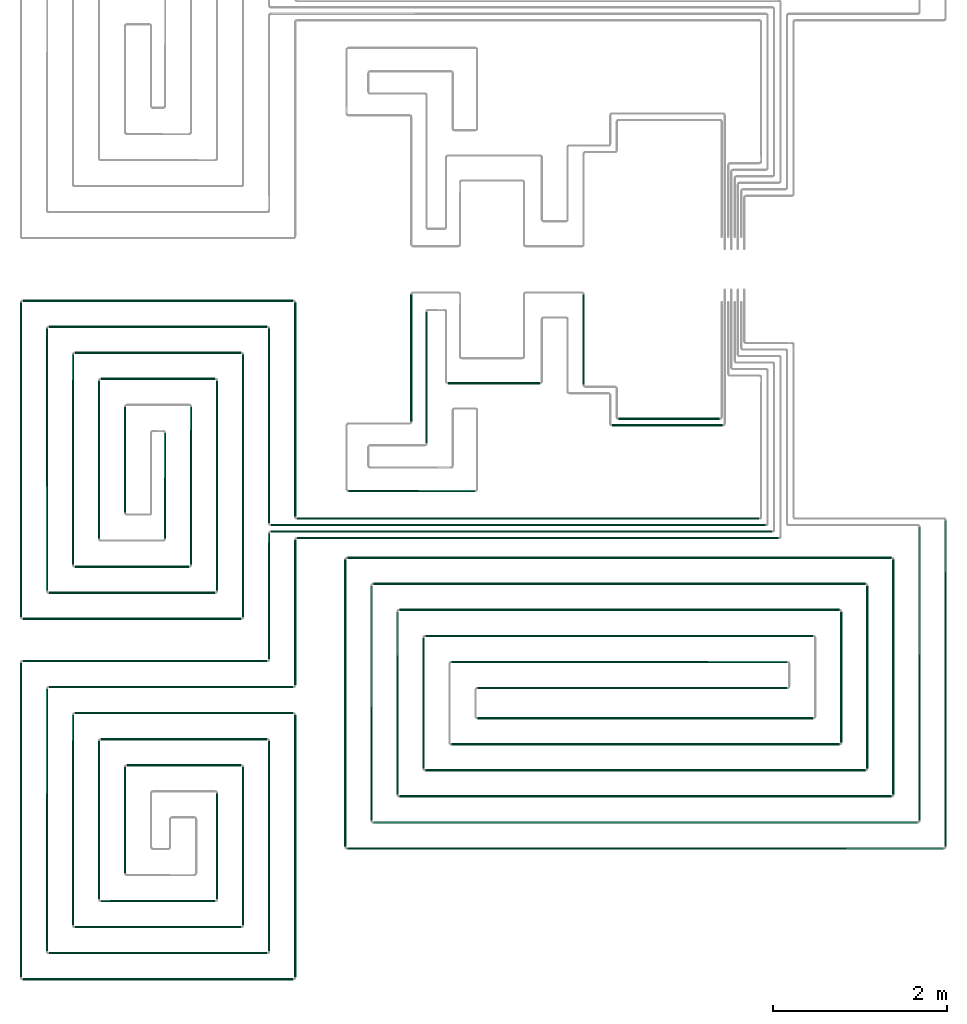
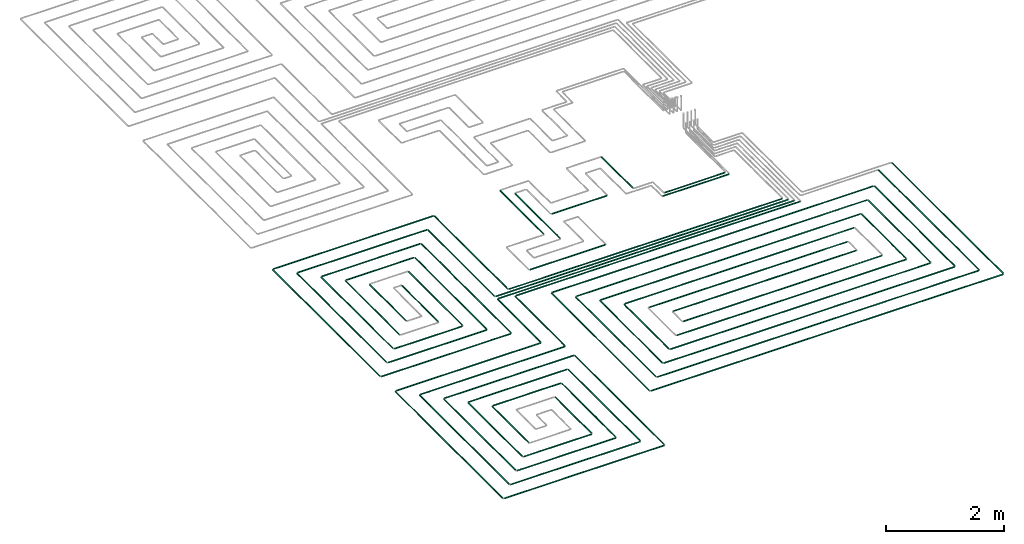
# One storey, part 1 of 12: 70 flow segments.
"""IFC2X3 building model written with IfcOpenShell, lengths in millimetres."""

from ifc_helpers import new_model, entity, si_unit, converted_unit, derived_unit, direction, frame, frame_2d, origin, origin_2d_with_axis, place, context, subcontext, project, spatial, circle, extrude, type_object, element, save


model = new_model("IFC2X3")

# Units and contexts
model_context = context("Model", 3, precision=0.01, world=origin(), true_north=direction((6.12303176911189e-17, 1.0)))
body_context = subcontext(model_context, "Body", "Model", "MODEL_VIEW")
ifc_project = project(units=[si_unit("LENGTHUNIT", "METRE", prefix="MILLI"), si_unit("AREAUNIT", "SQUARE_METRE"), si_unit("VOLUMEUNIT", "CUBIC_METRE"), converted_unit("PLANEANGLEUNIT", "DEGREE", entity("IfcRatioMeasure", 0.0174532925199433), si_unit("PLANEANGLEUNIT", "RADIAN"), dimensions=[0, 0, 0, 0, 0, 0, 0]), si_unit("MASSUNIT", "GRAM", prefix="KILO"), derived_unit("MASSDENSITYUNIT", [(si_unit("MASSUNIT", "GRAM", prefix="KILO"), 1), (si_unit("LENGTHUNIT", "METRE"), -3)]), si_unit("TIMEUNIT", "SECOND"), si_unit("FREQUENCYUNIT", "HERTZ"), si_unit("THERMODYNAMICTEMPERATUREUNIT", "DEGREE_CELSIUS"), derived_unit("THERMALTRANSMITTANCEUNIT", [(si_unit("MASSUNIT", "GRAM", prefix="KILO"), 1), (si_unit("THERMODYNAMICTEMPERATUREUNIT", "KELVIN"), -1), (si_unit("TIMEUNIT", "SECOND"), -3)]), derived_unit("VOLUMETRICFLOWRATEUNIT", [(si_unit("LENGTHUNIT", "METRE"), 3), (si_unit("TIMEUNIT", "SECOND"), -1)]), si_unit("ELECTRICCURRENTUNIT", "AMPERE"), si_unit("ELECTRICVOLTAGEUNIT", "VOLT"), si_unit("POWERUNIT", "WATT"), si_unit("FORCEUNIT", "NEWTON", prefix="KILO"), si_unit("ILLUMINANCEUNIT", "LUX"), si_unit("LUMINOUSFLUXUNIT", "LUMEN"), si_unit("LUMINOUSINTENSITYUNIT", "CANDELA"), derived_unit("USERDEFINED", [(si_unit("MASSUNIT", "GRAM", prefix="KILO"), -1), (si_unit("LENGTHUNIT", "METRE"), -2), (si_unit("TIMEUNIT", "SECOND"), 3), (si_unit("LUMINOUSFLUXUNIT", "LUMEN"), 1)]), derived_unit("LINEARVELOCITYUNIT", [(si_unit("LENGTHUNIT", "METRE"), 1), (si_unit("TIMEUNIT", "SECOND"), -1)]), si_unit("PRESSUREUNIT", "PASCAL"), derived_unit("USERDEFINED", [(si_unit("LENGTHUNIT", "METRE"), -2), (si_unit("MASSUNIT", "GRAM", prefix="KILO"), 1), (si_unit("TIMEUNIT", "SECOND"), -2)])], contexts=[model_context])

# Site, building, storey
site_placement = place(None, origin())
site = spatial("IfcSite", under=ifc_project, at=site_placement, CompositionType="ELEMENT")
building_placement = place(site_placement, origin())
building = spatial("IfcBuilding", under=site, at=building_placement, CompositionType="ELEMENT")
storey_placement = place(building_placement, frame((0.0, 0.0, 8000.0)))
storey = spatial("IfcBuildingStorey", under=building, at=storey_placement, Name="02 Level", CompositionType="ELEMENT", Elevation=8000.0)

# Flow segments
pipe_segment_type = type_object("IfcPipeSegmentType", PredefinedType="NOTDEFINED")
flow_segment_1_placement = place(storey_placement, frame((20884.4386293741, -71711.6450070283, -81.595272235917)))
element("IfcFlowSegment", 1, at=flow_segment_1_placement, inside=storey, type_object=pipe_segment_type, context=body_context, shape_type="SweptSolid", body=[
    extrude(circle(Radius=10.0, at=frame_2d((-8.66293703438714e-12, 0.0), x_axis=(1.0, 0.0))), frame((0.0, 11.5952722359136, 11.5952722359158), z_axis=(1.0, 0.0, 0.0), x_axis=(0.0, 1.0, 0.0)), (0.0, 0.0, 1.0), 5324.24692007345),
])
flow_segment_2_placement = place(storey_placement, frame((20584.4386293741, -71786.6450070283, -81.5952722359161)))
element("IfcFlowSegment", 2, at=flow_segment_2_placement, inside=storey, type_object=pipe_segment_type, context=body_context, shape_type="SweptSolid", body=[
    extrude(circle(Radius=10.0, at=frame_2d((-8.66293703438714e-12, 0.0), x_axis=(1.0, 0.0))), frame((0.0, 11.5952722359223, 11.5952722359158), z_axis=(1.0, 0.0, 0.0), x_axis=(0.0, 1.0, 0.0)), (0.0, 0.0, 1.0), 5699.24692007345),
])
flow_segment_3_placement = place(storey_placement, frame((20584.4386293741, -71861.6450070283, -81.5952722359161)))
element("IfcFlowSegment", 3, at=flow_segment_3_placement, inside=storey, type_object=pipe_segment_type, context=body_context, shape_type="SweptSolid", body=[
    extrude(circle(Radius=10.0, at=frame_2d((-2.59888111031614e-11, 0.0), x_axis=(1.0, 0.0))), frame((0.0, 11.5952722359396, 11.5952722359158), z_axis=(1.0, 0.0, 0.0), x_axis=(0.0, 1.0, 0.0)), (0.0, 0.0, 1.0), 5774.24692007345),
])
flow_segment_4_placement = place(storey_placement, frame((20884.4386293741, -71936.6450070283, -81.5952722359161)))
element("IfcFlowSegment", 4, at=flow_segment_4_placement, inside=storey, type_object=pipe_segment_type, context=body_context, shape_type="SweptSolid", body=[
    extrude(circle(Radius=10.0, at=frame_2d((-1.73258740687743e-11, 0.0), x_axis=(1.0, 0.0))), frame((0.0, 11.595272235931, 11.5952722359158), z_axis=(1.0, 0.0, 0.0), x_axis=(0.0, 1.0, 0.0)), (0.0, 0.0, 1.0), 5549.24692007344),
])
flow_segment_5_placement = place(storey_placement, frame((20552.8433571382, -73321.2395851399, -81.5952722359179)))
element("IfcFlowSegment", 5, at=flow_segment_5_placement, inside=storey, type_object=pipe_segment_type, context=body_context, shape_type="SweptSolid", body=[
    extrude(circle(Radius=10.0, at=origin_2d_with_axis()), frame((11.595272235918, 0.0, 11.5952722359158), z_axis=(0.0, 1.0, 0.0), x_axis=(-1.0, 0.0, 0.0)), (0.0, 0.0, 1.0), 1451.18985034759),
])
flow_segment_6_placement = place(storey_placement, frame((20852.8433571382, -73621.2395851399, -81.5952722359179)))
element("IfcFlowSegment", 6, at=flow_segment_6_placement, inside=storey, type_object=pipe_segment_type, context=body_context, shape_type="SweptSolid", body=[
    extrude(circle(Radius=10.0, at=origin_2d_with_axis()), frame((11.5952722359223, 0.0, 11.5952722359158), z_axis=(0.0, 1.0, 0.0), x_axis=(-1.0, 0.0, 0.0)), (0.0, 0.0, 1.0), 1676.18985034759),
])
flow_segment_7_placement = place(storey_placement, frame((24586.730888343, -70562.9096240978, -81.5952722359252)))
element("IfcFlowSegment", 7, at=flow_segment_7_placement, inside=storey, type_object=pipe_segment_type, context=body_context, shape_type="SweptSolid", body=[
    extrude(circle(Radius=10.0, at=origin_2d_with_axis()), frame((0.0, 11.5952722359136, 11.5952722359158), z_axis=(1.0, 0.0, 0.0), x_axis=(0.0, -1.0, 0.0)), (0.0, 0.0, 1.0), 1169.30608362779),
])
flow_segment_8_placement = place(storey_placement, frame((20852.8433571382, -71680.0497347924, -81.595272235917)))
element("IfcFlowSegment", 8, at=flow_segment_8_placement, inside=storey, type_object=pipe_segment_type, context=body_context, shape_type="SweptSolid", body=[
    extrude(circle(Radius=10.0, at=frame_2d((-2.16573425859679e-11, 0.0), x_axis=(1.0, 0.0))), frame((11.5952722359396, 0.0, 11.5952722359158), z_axis=(0.0, 1.0, 0.0), x_axis=(-1.0, 0.0, 0.0)), (0.0, 0.0, 1.0), 2468.81014965244),
])
flow_segment_9_placement = place(storey_placement, frame((20552.8433571382, -71755.0497347924, -81.5952722359179)))
element("IfcFlowSegment", 9, at=flow_segment_9_placement, inside=storey, type_object=pipe_segment_type, context=body_context, shape_type="SweptSolid", body=[
    extrude(circle(Radius=10.0, at=origin_2d_with_axis()), frame((11.5952722359223, 0.0, 11.5952722359158), z_axis=(0.0, 1.0, 0.0), x_axis=(1.0, 0.0, 0.0)), (0.0, 0.0, 1.0), 2243.81014965244),
])
flow_segment_10_placement = place(storey_placement, frame((17725.6253473195, -69202.8348573759, -81.5952722359179)))
element("IfcFlowSegment", 10, at=flow_segment_10_placement, inside=storey, type_object=pipe_segment_type, context=body_context, shape_type="SweptSolid", body=[
    extrude(circle(Radius=10.0, at=frame_2d((-1.73258740687743e-11, 0.0), x_axis=(1.0, 0.0))), frame((0.0, 11.595272235931, 11.5952722359158), z_axis=(1.0, 0.0, 0.0), x_axis=(0.0, 1.0, 0.0)), (0.0, 0.0, 1.0), 3118.81328205467),
])
flow_segment_11_placement = place(storey_placement, frame((18025.6253473195, -69502.8348573758, -81.5952722359179)))
element("IfcFlowSegment", 11, at=flow_segment_11_placement, inside=storey, type_object=pipe_segment_type, context=body_context, shape_type="SweptSolid", body=[
    extrude(circle(Radius=10.0, at=frame_2d((-1.73258740687743e-11, 0.0), x_axis=(1.0, 0.0))), frame((0.0, 11.595272235931, 11.5952722359158), z_axis=(1.0, 0.0, 0.0), x_axis=(0.0, 1.0, 0.0)), (0.0, 0.0, 1.0), 2518.81328205467),
])
flow_segment_12_placement = place(storey_placement, frame((17994.0300750835, -72534.5978364231, -81.5952722359198)))
element("IfcFlowSegment", 12, at=flow_segment_12_placement, inside=storey, type_object=pipe_segment_type, context=body_context, shape_type="SweptSolid", body=[
    extrude(circle(Radius=10.0, at=frame_2d((-2.38230768445646e-11, 0.0), x_axis=(1.0, 0.0))), frame((11.5952722359396, 0.0, 11.5952722359158), z_axis=(0.0, 1.0, 0.0), x_axis=(-1.0, 0.0, 0.0)), (0.0, 0.0, 1.0), 3023.35825128324),
])
flow_segment_13_placement = place(storey_placement, frame((17694.0300750835, -72834.5978364231, -81.5952722359198)))
element("IfcFlowSegment", 13, at=flow_segment_13_placement, inside=storey, type_object=pipe_segment_type, context=body_context, shape_type="SweptSolid", body=[
    extrude(circle(Radius=10.0, at=frame_2d((-2.16573425859679e-11, 0.0), x_axis=(1.0, 0.0))), frame((11.5952722359374, 0.0, 11.5952722359158), z_axis=(0.0, 1.0, 0.0), x_axis=(-1.0, 0.0, 0.0)), (0.0, 0.0, 1.0), 3623.35825128323),
])
flow_segment_14_placement = place(storey_placement, frame((18025.6253473194, -72566.1931086591, -81.5952722359179)))
element("IfcFlowSegment", 14, at=flow_segment_14_placement, inside=storey, type_object=pipe_segment_type, context=body_context, shape_type="SweptSolid", body=[
    extrude(circle(Radius=10.0, at=frame_2d((-8.66293703438714e-12, 0.0), x_axis=(1.0, 0.0))), frame((0.0, 11.5952722359223, 11.5952722359158), z_axis=(1.0, 0.0, 0.0), x_axis=(0.0, 1.0, 0.0)), (0.0, 0.0, 1.0), 1918.81328205468),
])
flow_segment_15_placement = place(storey_placement, frame((17725.6253473194, -72866.1931086591, -81.595272235917)))
element("IfcFlowSegment", 15, at=flow_segment_15_placement, inside=storey, type_object=pipe_segment_type, context=body_context, shape_type="SweptSolid", body=[
    extrude(circle(Radius=10.0, at=frame_2d((-8.66293703438714e-12, 0.0), x_axis=(1.0, 0.0))), frame((0.0, 11.595272235931, 11.5952722359158), z_axis=(1.0, 0.0, 0.0), x_axis=(0.0, 1.0, 0.0)), (0.0, 0.0, 1.0), 2518.81328205467),
])
flow_segment_16_placement = place(storey_placement, frame((20252.8433571382, -72834.5978364231, -81.5952722359216)))
element("IfcFlowSegment", 16, at=flow_segment_16_placement, inside=storey, type_object=pipe_segment_type, context=body_context, shape_type="SweptSolid", body=[
    extrude(circle(Radius=10.0, at=frame_2d((-2.59888111031614e-11, 0.0), x_axis=(1.0, 0.0))), frame((11.5952722359396, 0.0, 11.5952722359158), z_axis=(0.0, 1.0, 0.0), x_axis=(-1.0, 0.0, 0.0)), (0.0, 0.0, 1.0), 3023.35825128323),
])
flow_segment_17_placement = place(storey_placement, frame((19952.8433571382, -72534.5978364231, -81.5952722359179)))
element("IfcFlowSegment", 17, at=flow_segment_17_placement, inside=storey, type_object=pipe_segment_type, context=body_context, shape_type="SweptSolid", body=[
    extrude(circle(Radius=10.0, at=origin_2d_with_axis()), frame((11.5952722359223, 0.0, 11.5952722359158), z_axis=(0.0, 1.0, 0.0), x_axis=(1.0, 0.0, 0.0)), (0.0, 0.0, 1.0), 2423.35825128325),
])
flow_segment_18_placement = place(storey_placement, frame((18325.6253473194, -69802.8348573758, -81.5952722359216)))
element("IfcFlowSegment", 18, at=flow_segment_18_placement, inside=storey, type_object=pipe_segment_type, context=body_context, shape_type="SweptSolid", body=[
    extrude(circle(Radius=10.0, at=origin_2d_with_axis()), frame((0.0, 11.5952722359396, 11.5952722359158), z_axis=(1.0, 0.0, 0.0), x_axis=(0.0, -1.0, 0.0)), (0.0, 0.0, 1.0), 1918.8132820547),
])
flow_segment_19_placement = place(storey_placement, frame((18625.6253473194, -70102.8348573758, -81.5952722359189)))
element("IfcFlowSegment", 19, at=flow_segment_19_placement, inside=storey, type_object=pipe_segment_type, context=body_context, shape_type="SweptSolid", body=[
    extrude(circle(Radius=10.0, at=frame_2d((-8.66293703438714e-12, 0.0), x_axis=(1.0, 0.0))), frame((0.0, 11.5952722359223, 11.5952722359158), z_axis=(1.0, 0.0, 0.0), x_axis=(0.0, 1.0, 0.0)), (0.0, 0.0, 1.0), 1318.8132820547),
])
flow_segment_20_placement = place(storey_placement, frame((18594.0300750835, -71934.5978364232, -81.5952722359216)))
element("IfcFlowSegment", 20, at=flow_segment_20_placement, inside=storey, type_object=pipe_segment_type, context=body_context, shape_type="SweptSolid", body=[
    extrude(circle(Radius=10.0, at=frame_2d((-1.94916083273711e-11, 0.0), x_axis=(1.0, 0.0))), frame((11.5952722359353, 0.0, 11.5952722359158), z_axis=(0.0, 1.0, 0.0), x_axis=(-1.0, 0.0, 0.0)), (0.0, 0.0, 1.0), 1823.35825128327),
])
flow_segment_21_placement = place(storey_placement, frame((18294.0300750835, -72234.5978364231, -81.5952722359198)))
element("IfcFlowSegment", 21, at=flow_segment_21_placement, inside=storey, type_object=pipe_segment_type, context=body_context, shape_type="SweptSolid", body=[
    extrude(circle(Radius=10.0, at=frame_2d((-1.94916083273711e-11, 0.0), x_axis=(1.0, 0.0))), frame((11.5952722359353, 0.0, 11.5952722359158), z_axis=(0.0, 1.0, 0.0), x_axis=(-1.0, 0.0, 0.0)), (0.0, 0.0, 1.0), 2423.35825128326),
])
flow_segment_22_placement = place(storey_placement, frame((18325.6253473194, -72266.1931086591, -81.5952722359216)))
element("IfcFlowSegment", 22, at=flow_segment_22_placement, inside=storey, type_object=pipe_segment_type, context=body_context, shape_type="SweptSolid", body=[
    extrude(circle(Radius=10.0, at=frame_2d((-8.66293703438714e-12, 0.0), x_axis=(1.0, 0.0))), frame((0.0, 11.5952722359223, 11.5952722359158), z_axis=(1.0, 0.0, 0.0), x_axis=(0.0, 1.0, 0.0)), (0.0, 0.0, 1.0), 1318.81328205471),
])
flow_segment_23_placement = place(storey_placement, frame((19652.8433571382, -72234.5978364232, -81.5952722359234)))
element("IfcFlowSegment", 23, at=flow_segment_23_placement, inside=storey, type_object=pipe_segment_type, context=body_context, shape_type="SweptSolid", body=[
    extrude(circle(Radius=10.0, at=frame_2d((-1.29944055515807e-11, 0.0), x_axis=(1.0, 0.0))), frame((11.595272235931, 0.0, 11.5952722359158), z_axis=(0.0, 1.0, 0.0), x_axis=(-1.0, 0.0, 0.0)), (0.0, 0.0, 1.0), 1823.35825128327),
])
flow_segment_24_placement = place(storey_placement, frame((19352.8433571382, -71934.5978364232, -81.5952722359225)))
element("IfcFlowSegment", 24, at=flow_segment_24_placement, inside=storey, type_object=pipe_segment_type, context=body_context, shape_type="SweptSolid", body=[
    extrude(circle(Radius=10.0, at=frame_2d((-8.66293703438714e-12, 0.0), x_axis=(1.0, 0.0))), frame((11.5952722359245, 0.0, 11.5952722359158), z_axis=(0.0, 1.0, 0.0), x_axis=(-1.0, 0.0, 0.0)), (0.0, 0.0, 1.0), 1223.35825128328),
])
flow_segment_25_placement = place(storey_placement, frame((18894.0300750835, -71634.5978364232, -81.5952722359234)))
element("IfcFlowSegment", 25, at=flow_segment_25_placement, inside=storey, type_object=pipe_segment_type, context=body_context, shape_type="SweptSolid", body=[
    extrude(circle(Radius=10.0, at=frame_2d((-1.51601398101775e-11, 0.0), x_axis=(1.0, 0.0))), frame((11.595272235931, 0.0, 11.5952722359158), z_axis=(0.0, 1.0, 0.0), x_axis=(-1.0, 0.0, 0.0)), (0.0, 0.0, 1.0), 1223.35825128332),
])
flow_segment_26_placement = place(storey_placement, frame((20852.8433571382, -76984.5978364232, -81.5952722359179)))
element("IfcFlowSegment", 26, at=flow_segment_26_placement, inside=storey, type_object=pipe_segment_type, context=body_context, shape_type="SweptSolid", body=[
    extrude(circle(Radius=10.0, at=frame_2d((-2.59888111031614e-11, 0.0), x_axis=(1.0, 0.0))), frame((11.5952722359353, 0.0, 11.5952722359158), z_axis=(0.0, 1.0, 0.0), x_axis=(-1.0, 0.0, 0.0)), (0.0, 0.0, 1.0), 3023.35825128325),
])
flow_segment_27_placement = place(storey_placement, frame((20552.8433571382, -76684.5978364232, -81.595272235917)))
element("IfcFlowSegment", 27, at=flow_segment_27_placement, inside=storey, type_object=pipe_segment_type, context=body_context, shape_type="SweptSolid", body=[
    extrude(circle(Radius=10.0, at=origin_2d_with_axis()), frame((11.595272235918, 0.0, 11.5952722359158), z_axis=(0.0, 1.0, 0.0), x_axis=(1.0, 0.0, 0.0)), (0.0, 0.0, 1.0), 2423.35825128326),
])
flow_segment_28_placement = place(storey_placement, frame((17994.0300750835, -76684.5978364232, -81.5952722359216)))
element("IfcFlowSegment", 28, at=flow_segment_28_placement, inside=storey, type_object=pipe_segment_type, context=body_context, shape_type="SweptSolid", body=[
    extrude(circle(Radius=10.0, at=frame_2d((-2.81545453617582e-11, 0.0), x_axis=(1.0, 0.0))), frame((11.5952722359439, 0.0, 11.5952722359158), z_axis=(0.0, 1.0, 0.0), x_axis=(-1.0, 0.0, 0.0)), (0.0, 0.0, 1.0), 3023.35825128327),
])
flow_segment_29_placement = place(storey_placement, frame((17694.0300750835, -76984.5978364231, -81.5952722359216)))
element("IfcFlowSegment", 29, at=flow_segment_29_placement, inside=storey, type_object=pipe_segment_type, context=body_context, shape_type="SweptSolid", body=[
    extrude(circle(Radius=10.0, at=frame_2d((-2.81545453617582e-11, 0.0), x_axis=(1.0, 0.0))), frame((11.5952722359418, 0.0, 11.5952722359158), z_axis=(0.0, 1.0, 0.0), x_axis=(-1.0, 0.0, 0.0)), (0.0, 0.0, 1.0), 3623.35825128325),
])
flow_segment_30_placement = place(storey_placement, frame((20252.8433571382, -76384.5978364232, -81.5952722359234)))
element("IfcFlowSegment", 30, at=flow_segment_30_placement, inside=storey, type_object=pipe_segment_type, context=body_context, shape_type="SweptSolid", body=[
    extrude(circle(Radius=10.0, at=frame_2d((-2.16573425859679e-11, 0.0), x_axis=(1.0, 0.0))), frame((11.5952722359396, 0.0, 11.5952722359158), z_axis=(0.0, 1.0, 0.0), x_axis=(-1.0, 0.0, 0.0)), (0.0, 0.0, 1.0), 1823.35825128329),
])
flow_segment_31_placement = place(storey_placement, frame((19952.8433571382, -76084.5978364232, -81.5952722359189)))
element("IfcFlowSegment", 31, at=flow_segment_31_placement, inside=storey, type_object=pipe_segment_type, context=body_context, shape_type="SweptSolid", body=[
    extrude(circle(Radius=10.0, at=origin_2d_with_axis()), frame((11.595272235918, 0.0, 11.5952722359158), z_axis=(0.0, 1.0, 0.0), x_axis=(1.0, 0.0, 0.0)), (0.0, 0.0, 1.0), 1223.35825128325),
])
flow_segment_32_placement = place(storey_placement, frame((18594.0300750835, -76084.5978364232, -81.595272235928)))
element("IfcFlowSegment", 32, at=flow_segment_32_placement, inside=storey, type_object=pipe_segment_type, context=body_context, shape_type="SweptSolid", body=[
    extrude(circle(Radius=10.0, at=origin_2d_with_axis()), frame((11.5952722359158, 0.0, 11.5952722359158), z_axis=(0.0, 1.0, 0.0), x_axis=(1.0, 0.0, 0.0)), (0.0, 0.0, 1.0), 1823.35825128331),
])
flow_segment_33_placement = place(storey_placement, frame((18294.0300750835, -76384.5978364232, -81.5952722359252)))
element("IfcFlowSegment", 33, at=flow_segment_33_placement, inside=storey, type_object=pipe_segment_type, context=body_context, shape_type="SweptSolid", body=[
    extrude(circle(Radius=10.0, at=origin_2d_with_axis()), frame((11.5952722359158, 0.0, 11.5952722359158), z_axis=(0.0, 1.0, 0.0), x_axis=(1.0, 0.0, 0.0)), (0.0, 0.0, 1.0), 2423.35825128329),
])
flow_segment_34_placement = place(storey_placement, frame((18894.0300750835, -75784.5978364232, -81.5952722359243)))
element("IfcFlowSegment", 34, at=flow_segment_34_placement, inside=storey, type_object=pipe_segment_type, context=body_context, shape_type="SweptSolid", body=[
    extrude(circle(Radius=10.0, at=frame_2d((-2.16573425859679e-11, 0.0), x_axis=(1.0, 0.0))), frame((11.5952722359353, 0.0, 11.5952722359158), z_axis=(0.0, 1.0, 0.0), x_axis=(-1.0, 0.0, 0.0)), (0.0, 0.0, 1.0), 1223.35825128335),
])
for number, where in (
    (35, (17725.6253473195, -73352.8348573759, -81.5952722359161)),
    (36, (18025.6253473194, -73652.8348573759, -81.595272235917)),
):
    element("IfcFlowSegment", number, at=place(storey_placement, frame(where)), inside=storey, type_object=pipe_segment_type, context=body_context, shape_type="SweptSolid", body=[
        extrude(circle(Radius=10.0, at=frame_2d((-3.46517481375486e-11, 0.0), x_axis=(1.0, 0.0))), frame((0.0, 11.5952722359483, 11.5952722359158), z_axis=(1.0, 0.0, 0.0), x_axis=(0.0, 1.0, 0.0)), (0.0, 0.0, 1.0), 2818.81328205464),
    ])
flow_segment_35_placement = place(storey_placement, frame((18025.6253473194, -76716.1931086591, -81.5952722359179)))
element("IfcFlowSegment", 37, at=flow_segment_35_placement, inside=storey, type_object=pipe_segment_type, context=body_context, shape_type="SweptSolid", body=[
    extrude(circle(Radius=10.0, at=frame_2d((-8.66293703438714e-12, 0.0), x_axis=(1.0, 0.0))), frame((0.0, 11.5952722359136, 11.5952722359158), z_axis=(1.0, 0.0, 0.0), x_axis=(0.0, 1.0, 0.0)), (0.0, 0.0, 1.0), 2518.8132820547),
])
flow_segment_36_placement = place(storey_placement, frame((17725.6253473194, -77016.1931086591, -81.5952722359161)))
element("IfcFlowSegment", 38, at=flow_segment_36_placement, inside=storey, type_object=pipe_segment_type, context=body_context, shape_type="SweptSolid", body=[
    extrude(circle(Radius=10.0, at=frame_2d((-8.66293703438714e-12, 0.0), x_axis=(1.0, 0.0))), frame((0.0, 11.595272235931, 11.5952722359158), z_axis=(1.0, 0.0, 0.0), x_axis=(0.0, 1.0, 0.0)), (0.0, 0.0, 1.0), 3118.81328205468),
])
flow_segment_37_placement = place(storey_placement, frame((18325.6253473194, -73952.8348573758, -81.5952722359189)))
element("IfcFlowSegment", 39, at=flow_segment_37_placement, inside=storey, type_object=pipe_segment_type, context=body_context, shape_type="SweptSolid", body=[
    extrude(circle(Radius=10.0, at=frame_2d((-1.73258740687743e-11, 0.0), x_axis=(1.0, 0.0))), frame((0.0, 11.595272235931, 11.5952722359158), z_axis=(1.0, 0.0, 0.0), x_axis=(0.0, 1.0, 0.0)), (0.0, 0.0, 1.0), 2518.8132820547),
])
flow_segment_38_placement = place(storey_placement, frame((18625.6253473194, -74252.8348573758, -81.5952722359189)))
element("IfcFlowSegment", 40, at=flow_segment_38_placement, inside=storey, type_object=pipe_segment_type, context=body_context, shape_type="SweptSolid", body=[
    extrude(circle(Radius=10.0, at=frame_2d((-1.73258740687743e-11, 0.0), x_axis=(1.0, 0.0))), frame((0.0, 11.595272235931, 11.5952722359158), z_axis=(1.0, 0.0, 0.0), x_axis=(0.0, 1.0, 0.0)), (0.0, 0.0, 1.0), 1918.8132820547),
])
flow_segment_39_placement = place(storey_placement, frame((18625.6253473194, -76116.1931086591, -81.5952722359198)))
element("IfcFlowSegment", 41, at=flow_segment_39_placement, inside=storey, type_object=pipe_segment_type, context=body_context, shape_type="SweptSolid", body=[
    extrude(circle(Radius=10.0, at=origin_2d_with_axis()), frame((0.0, 11.5952722359136, 11.5952722359158), z_axis=(1.0, 0.0, 0.0), x_axis=(0.0, 1.0, 0.0)), (0.0, 0.0, 1.0), 1318.81328205473),
])
flow_segment_40_placement = place(storey_placement, frame((18325.6253473194, -76416.1931086591, -81.5952722359189)))
element("IfcFlowSegment", 42, at=flow_segment_40_placement, inside=storey, type_object=pipe_segment_type, context=body_context, shape_type="SweptSolid", body=[
    extrude(circle(Radius=10.0, at=frame_2d((-8.66293703438714e-12, 0.0), x_axis=(1.0, 0.0))), frame((0.0, 11.5952722359223, 11.5952722359158), z_axis=(1.0, 0.0, 0.0), x_axis=(0.0, 1.0, 0.0)), (0.0, 0.0, 1.0), 1918.81328205471),
])
flow_segment_41_placement = place(storey_placement, frame((18925.6253473194, -74552.8348573758, -81.5952722359225)))
element("IfcFlowSegment", 43, at=flow_segment_41_placement, inside=storey, type_object=pipe_segment_type, context=body_context, shape_type="SweptSolid", body=[
    extrude(circle(Radius=10.0, at=frame_2d((-8.66293703438714e-12, 0.0), x_axis=(1.0, 0.0))), frame((0.0, 11.5952722359223, 11.5952722359158), z_axis=(1.0, 0.0, 0.0), x_axis=(0.0, 1.0, 0.0)), (0.0, 0.0, 1.0), 1318.81328205473),
])
flow_segment_42_placement = place(storey_placement, frame((28341.5018091839, -75479.8436457932, -81.5952722359161)))
element("IfcFlowSegment", 44, at=flow_segment_42_placement, inside=storey, type_object=pipe_segment_type, context=body_context, shape_type="SweptSolid", body=[
    extrude(circle(Radius=10.0, at=origin_2d_with_axis()), frame((11.595272235918, 0.0, 11.5952722359158), z_axis=(0.0, 1.0, 0.0), x_axis=(1.0, 0.0, 0.0)), (0.0, 0.0, 1.0), 3759.79391100087),
])
flow_segment_43_placement = place(storey_placement, frame((28041.5018091839, -75179.8436457933, -81.5952722359179)))
element("IfcFlowSegment", 45, at=flow_segment_43_placement, inside=storey, type_object=pipe_segment_type, context=body_context, shape_type="SweptSolid", body=[
    extrude(circle(Radius=10.0, at=frame_2d((-2.59888111031614e-11, 0.0), x_axis=(1.0, 0.0))), frame((11.5952722359526, 0.0, 11.5952722359158), z_axis=(0.0, 1.0, 0.0), x_axis=(-1.0, 0.0, 0.0)), (0.0, 0.0, 1.0), 3384.79391100087),
])
flow_segment_44_placement = place(storey_placement, frame((27741.5018091839, -74879.8436457933, -81.595272235917)))
element("IfcFlowSegment", 46, at=flow_segment_44_placement, inside=storey, type_object=pipe_segment_type, context=body_context, shape_type="SweptSolid", body=[
    extrude(circle(Radius=10.0, at=origin_2d_with_axis()), frame((11.5952722359223, 0.0, 11.5952722359158), z_axis=(0.0, 1.0, 0.0), x_axis=(1.0, 0.0, 0.0)), (0.0, 0.0, 1.0), 2707.85893213088),
])
flow_segment_45_placement = place(storey_placement, frame((27441.5018091839, -74579.8436457933, -81.5952722359161)))
element("IfcFlowSegment", 47, at=flow_segment_45_placement, inside=storey, type_object=pipe_segment_type, context=body_context, shape_type="SweptSolid", body=[
    extrude(circle(Radius=10.0, at=frame_2d((-2.16573425859679e-11, 0.0), x_axis=(1.0, 0.0))), frame((11.5952722359396, 0.0, 11.5952722359158), z_axis=(0.0, 1.0, 0.0), x_axis=(-1.0, 0.0, 0.0)), (0.0, 0.0, 1.0), 2107.85893213088),
])
flow_segment_46_placement = place(storey_placement, frame((21730.6562350407, -75179.8436457932, -81.595272235927)))
element("IfcFlowSegment", 48, at=flow_segment_46_placement, inside=storey, type_object=pipe_segment_type, context=body_context, shape_type="SweptSolid", body=[
    extrude(circle(Radius=10.0, at=frame_2d((-3.46517481375486e-11, 0.0), x_axis=(1.0, 0.0))), frame((11.5952722359526, 0.0, 11.5952722359158), z_axis=(0.0, 1.0, 0.0), x_axis=(-1.0, 0.0, 0.0)), (0.0, 0.0, 1.0), 2707.85893213097),
])
flow_segment_47_placement = place(storey_placement, frame((21430.6562350407, -75479.8436457932, -81.595272235927)))
element("IfcFlowSegment", 49, at=flow_segment_47_placement, inside=storey, type_object=pipe_segment_type, context=body_context, shape_type="SweptSolid", body=[
    extrude(circle(Radius=10.0, at=frame_2d((-2.59888111031614e-11, 0.0), x_axis=(1.0, 0.0))), frame((11.5952722359483, 0.0, 11.5952722359158), z_axis=(0.0, 1.0, 0.0), x_axis=(-1.0, 0.0, 0.0)), (0.0, 0.0, 1.0), 3307.85893213096),
])
flow_segment_48_placement = place(storey_placement, frame((22330.6562350407, -74579.8436457932, -81.5952722359307)))
element("IfcFlowSegment", 50, at=flow_segment_48_placement, inside=storey, type_object=pipe_segment_type, context=body_context, shape_type="SweptSolid", body=[
    extrude(circle(Radius=10.0, at=frame_2d((-2.59888111031614e-11, 0.0), x_axis=(1.0, 0.0))), frame((11.5952722359353, 0.0, 11.5952722359158), z_axis=(0.0, 1.0, 0.0), x_axis=(-1.0, 0.0, 0.0)), (0.0, 0.0, 1.0), 1507.858932131),
])
flow_segment_49_placement = place(storey_placement, frame((22030.6562350407, -74879.8436457932, -81.5952722359316)))
element("IfcFlowSegment", 51, at=flow_segment_49_placement, inside=storey, type_object=pipe_segment_type, context=body_context, shape_type="SweptSolid", body=[
    extrude(circle(Radius=10.0, at=frame_2d((-2.16573425859679e-11, 0.0), x_axis=(1.0, 0.0))), frame((11.5952722359396, 0.0, 11.5952722359158), z_axis=(0.0, 1.0, 0.0), x_axis=(-1.0, 0.0, 0.0)), (0.0, 0.0, 1.0), 2107.85893213099),
])
flow_segment_50_placement = place(storey_placement, frame((21762.2515072766, -75211.4389180292, -81.595272235927)))
element("IfcFlowSegment", 52, at=flow_segment_50_placement, inside=storey, type_object=pipe_segment_type, context=body_context, shape_type="SweptSolid", body=[
    extrude(circle(Radius=10.0, at=origin_2d_with_axis()), frame((0.0, 11.5952722359483, 11.5952722359158), z_axis=(1.0, 0.0, 0.0), x_axis=(0.0, -1.0, 0.0)), (0.0, 0.0, 1.0), 6270.84557414324),
])
flow_segment_51_placement = place(storey_placement, frame((21462.2515072766, -75511.4389180292, -81.5952722359143)))
element("IfcFlowSegment", 53, at=flow_segment_51_placement, inside=storey, type_object=pipe_segment_type, context=body_context, shape_type="SweptSolid", body=[
    extrude(circle(Radius=10.0, at=frame_2d((-2.59888111031614e-11, 0.0), x_axis=(1.0, 0.0))), frame((0.0, 11.5952722359396, 11.5952722359158), z_axis=(1.0, 0.0, 0.0), x_axis=(0.0, 1.0, 0.0)), (0.0, 0.0, 1.0), 6870.84557414322),
])
flow_segment_52_placement = place(storey_placement, frame((22362.2515072766, -74611.4389180292, -81.5952722359225)))
element("IfcFlowSegment", 54, at=flow_segment_52_placement, inside=storey, type_object=pipe_segment_type, context=body_context, shape_type="SweptSolid", body=[
    extrude(circle(Radius=10.0, at=frame_2d((-8.66293703438714e-12, 0.0), x_axis=(1.0, 0.0))), frame((0.0, 11.5952722359223, 11.5952722359158), z_axis=(1.0, 0.0, 0.0), x_axis=(0.0, 1.0, 0.0)), (0.0, 0.0, 1.0), 5070.84557414327),
])
flow_segment_53_placement = place(storey_placement, frame((22062.2515072766, -74911.4389180292, -81.5952722359289)))
element("IfcFlowSegment", 55, at=flow_segment_53_placement, inside=storey, type_object=pipe_segment_type, context=body_context, shape_type="SweptSolid", body=[
    extrude(circle(Radius=10.0, at=origin_2d_with_axis()), frame((0.0, 11.5952722359656, 11.5952722359158), z_axis=(1.0, 0.0, 0.0), x_axis=(0.0, -1.0, 0.0)), (0.0, 0.0, 1.0), 5670.84557414326),
])
flow_segment_54_placement = place(storey_placement, frame((21462.2515072766, -72163.5799858983, -81.595272235927)))
element("IfcFlowSegment", 56, at=flow_segment_54_placement, inside=storey, type_object=pipe_segment_type, context=body_context, shape_type="SweptSolid", body=[
    extrude(circle(Radius=10.0, at=frame_2d((-7.79664333094843e-11, 0.0), x_axis=(1.0, 0.0))), frame((0.0, 11.5952722359916, 11.5952722359158), z_axis=(1.0, 0.0, 0.0), x_axis=(0.0, 1.0, 0.0)), (0.0, 0.0, 1.0), 6270.84557414324),
])
flow_segment_55_placement = place(storey_placement, frame((21762.2515072766, -72463.5799858983, -81.5952722359161)))
element("IfcFlowSegment", 57, at=flow_segment_55_placement, inside=storey, type_object=pipe_segment_type, context=body_context, shape_type="SweptSolid", body=[
    extrude(circle(Radius=10.0, at=frame_2d((-6.064055924071e-11, 0.0), x_axis=(1.0, 0.0))), frame((0.0, 11.5952722359829, 11.5952722359158), z_axis=(1.0, 0.0, 0.0), x_axis=(0.0, 1.0, 0.0)), (0.0, 0.0, 1.0), 5670.84557414323),
])
flow_segment_56_placement = place(storey_placement, frame((22062.2515072766, -72763.5799858982, -81.5952722359234)))
element("IfcFlowSegment", 58, at=flow_segment_56_placement, inside=storey, type_object=pipe_segment_type, context=body_context, shape_type="SweptSolid", body=[
    extrude(circle(Radius=10.0, at=frame_2d((-5.19776222063229e-11, 0.0), x_axis=(1.0, 0.0))), frame((0.0, 11.5952722359656, 11.5952722359158), z_axis=(1.0, 0.0, 0.0), x_axis=(0.0, 1.0, 0.0)), (0.0, 0.0, 1.0), 5070.84557414326),
])
flow_segment_57_placement = place(storey_placement, frame((22362.2515072766, -73063.5799858982, -81.5952722359189)))
element("IfcFlowSegment", 59, at=flow_segment_57_placement, inside=storey, type_object=pipe_segment_type, context=body_context, shape_type="SweptSolid", body=[
    extrude(circle(Radius=10.0, at=frame_2d((-4.33146851719357e-11, 0.0), x_axis=(1.0, 0.0))), frame((0.0, 11.5952722359569, 11.5952722359158), z_axis=(1.0, 0.0, 0.0), x_axis=(0.0, 1.0, 0.0)), (0.0, 0.0, 1.0), 4470.84557414325),
])
flow_segment_58_placement = place(storey_placement, frame((27141.5018091839, -74279.8436457933, -81.5952722359198)))
element("IfcFlowSegment", 60, at=flow_segment_58_placement, inside=storey, type_object=pipe_segment_type, context=body_context, shape_type="SweptSolid", body=[
    extrude(circle(Radius=10.0, at=origin_2d_with_axis()), frame((11.595272235918, 0.0, 11.5952722359158), z_axis=(0.0, 1.0, 0.0), x_axis=(1.0, 0.0, 0.0)), (0.0, 0.0, 1.0), 1507.85893213094),
])
flow_segment_59_placement = place(storey_placement, frame((22962.2515072765, -74011.4389180292, -81.5952722359389)))
element("IfcFlowSegment", 61, at=flow_segment_59_placement, inside=storey, type_object=pipe_segment_type, context=body_context, shape_type="SweptSolid", body=[
    extrude(circle(Radius=10.0, at=origin_2d_with_axis()), frame((0.0, 11.595272235931, 11.5952722359158), z_axis=(1.0, 0.0, 0.0), x_axis=(0.0, -1.0, 0.0)), (0.0, 0.0, 1.0), 3870.84557414329),
])
flow_segment_60_placement = place(storey_placement, frame((22662.2515072766, -74311.4389180292, -81.5952722359316)))
element("IfcFlowSegment", 62, at=flow_segment_60_placement, inside=storey, type_object=pipe_segment_type, context=body_context, shape_type="SweptSolid", body=[
    extrude(circle(Radius=10.0, at=origin_2d_with_axis()), frame((0.0, 11.5952722359483, 11.5952722359158), z_axis=(1.0, 0.0, 0.0), x_axis=(0.0, -1.0, 0.0)), (0.0, 0.0, 1.0), 4470.84557414328),
])
flow_segment_61_placement = place(storey_placement, frame((22662.2515072766, -73363.5799858982, -81.5952722359252)))
element("IfcFlowSegment", 63, at=flow_segment_61_placement, inside=storey, type_object=pipe_segment_type, context=body_context, shape_type="SweptSolid", body=[
    extrude(circle(Radius=10.0, at=frame_2d((-4.33146851719357e-11, 0.0), x_axis=(1.0, 0.0))), frame((0.0, 11.5952722359569, 11.5952722359158), z_axis=(1.0, 0.0, 0.0), x_axis=(0.0, 1.0, 0.0)), (0.0, 0.0, 1.0), 3870.84557414328),
])
flow_segment_62_placement = place(storey_placement, frame((22962.2515072766, -73663.5799858983, -81.595272235927)))
element("IfcFlowSegment", 64, at=flow_segment_62_placement, inside=storey, type_object=pipe_segment_type, context=body_context, shape_type="SweptSolid", body=[
    extrude(circle(Radius=10.0, at=frame_2d((-5.19776222063229e-11, 0.0), x_axis=(1.0, 0.0))), frame((0.0, 11.5952722359656, 11.5952722359158), z_axis=(1.0, 0.0, 0.0), x_axis=(0.0, 1.0, 0.0)), (0.0, 0.0, 1.0), 3570.8455741433),
])
flow_segment_63_placement = place(storey_placement, frame((24174.4137837032, -70162.4616421941, -81.5952722359289)))
element("IfcFlowSegment", 65, at=flow_segment_63_placement, inside=storey, type_object=pipe_segment_type, context=body_context, shape_type="SweptSolid", body=[
    extrude(circle(Radius=10.0, at=frame_2d((-3.46517481375486e-11, 0.0), x_axis=(1.0, 0.0))), frame((11.5952722359483, 0.0, 11.5952722359158), z_axis=(0.0, 1.0, 0.0), x_axis=(-1.0, 0.0, 0.0)), (0.0, 0.0, 1.0), 1044.42186360162),
])
flow_segment_64_placement = place(storey_placement, frame((21476.9829033853, -71393.9202306541, -81.5952722359289)))
element("IfcFlowSegment", 66, at=flow_segment_64_placement, inside=storey, type_object=pipe_segment_type, context=body_context, shape_type="SweptSolid", body=[
    extrude(circle(Radius=10.0, at=origin_2d_with_axis()), frame((0.0, 11.5952722359136, 11.5952722359158), z_axis=(1.0, 0.0, 0.0), x_axis=(0.0, 1.0, 0.0)), (0.0, 0.0, 1.0), 1461.77751147482),
])
flow_segment_65_placement = place(storey_placement, frame((22190.153709968, -70586.2395851399, -81.5952722359289)))
element("IfcFlowSegment", 67, at=flow_segment_65_placement, inside=storey, type_object=pipe_segment_type, context=body_context, shape_type="SweptSolid", body=[
    extrude(circle(Radius=10.0, at=frame_2d((-1.29944055515807e-11, 0.0), x_axis=(1.0, 0.0))), frame((11.595272235931, 0.0, 11.5952722359158), z_axis=(0.0, 1.0, 0.0), x_axis=(-1.0, 0.0, 0.0)), (0.0, 0.0, 1.0), 1468.19980654745),
])
flow_segment_66_placement = place(storey_placement, frame((22365.153709968, -70836.2395851399, -81.5952722359225)))
element("IfcFlowSegment", 68, at=flow_segment_66_placement, inside=storey, type_object=pipe_segment_type, context=body_context, shape_type="SweptSolid", body=[
    extrude(circle(Radius=10.0, at=frame_2d((-1.29944055515807e-11, 0.0), x_axis=(1.0, 0.0))), frame((11.595272235931, 0.0, 11.5952722359158), z_axis=(0.0, 1.0, 0.0), x_axis=(-1.0, 0.0, 0.0)), (0.0, 0.0, 1.0), 1518.19980654744),
])
flow_segment_67_placement = place(storey_placement, frame((24511.730888343, -70637.9096240978, -81.5952722359243)))
element("IfcFlowSegment", 69, at=flow_segment_67_placement, inside=storey, type_object=pipe_segment_type, context=body_context, shape_type="SweptSolid", body=[
    extrude(circle(Radius=10.0, at=origin_2d_with_axis()), frame((0.0, 11.5952722359136, 11.5952722359158), z_axis=(1.0, 0.0, 0.0), x_axis=(0.0, -1.0, 0.0)), (0.0, 0.0, 1.0), 1279.3060836278),
])
flow_segment_68_placement = place(storey_placement, frame((22622.1485075651, -70152.8348573759, -81.5952722359334)))
element("IfcFlowSegment", 70, at=flow_segment_68_placement, inside=storey, type_object=pipe_segment_type, context=body_context, shape_type="SweptSolid", body=[
    extrude(circle(Radius=10.0, at=frame_2d((-1.73258740687743e-11, 0.0), x_axis=(1.0, 0.0))), frame((0.0, 11.595272235931, 11.5952722359158), z_axis=(1.0, 0.0, 0.0), x_axis=(0.0, 1.0, 0.0)), (0.0, 0.0, 1.0), 1062.80764523384),
])

save(model, "model.ifc")
